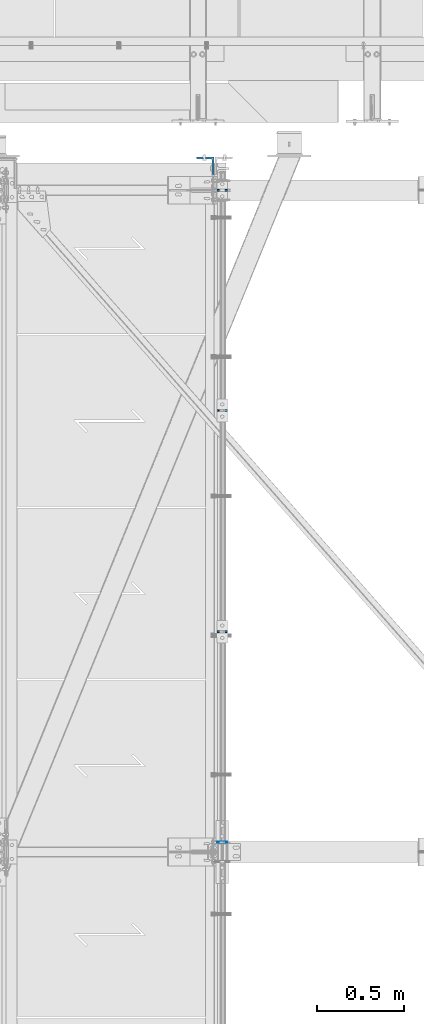
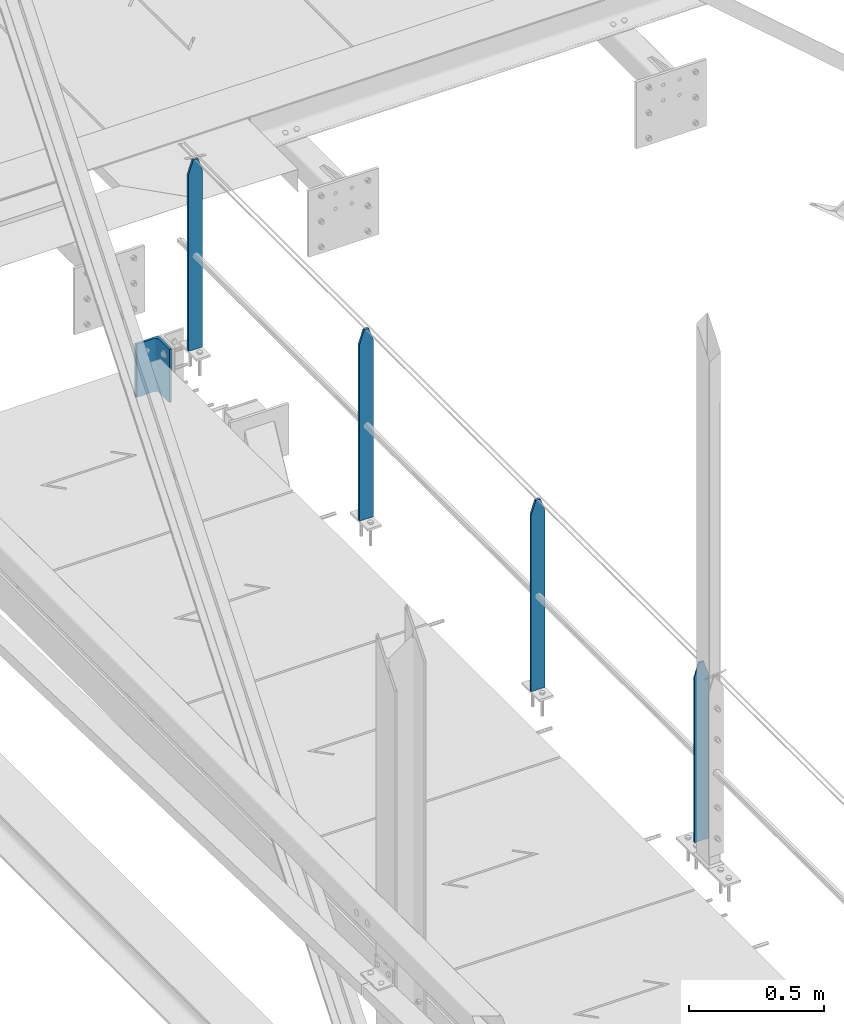
# One storey, part 27 of 496: 5 columns, 2 elements without a shape of their own.
"""IFC2X3 building model written with IfcOpenShell, lengths in millimetres."""

import ifcopenshell
import ifcopenshell.guid

model = None  # the IFC model being written
_history = None  # IfcOwnerHistory: only IFC2X3 demands one
_inside = {}  # id of a spatial element -> (the spatial element, [elements in it])
_under = {}  # id of a project, library or spatial element -> (it, [spatial elements below it])
_declared = {}  # id of a project -> (the project, [libraries it declares])
_typed = {}  # id of a type object -> (the type object, [elements of that type])
_made_of = {}  # id of a material, layer set ... -> (it, [elements and type objects made of it])


def new_model(schema):
    """Start an empty IFC model of exactly this schema.

    Asked for "IFC4X3", IfcOpenShell would pick the latest addendum, in which some entities
    have other attributes; the version numbers below select the first issue.
    IFC2X3 requires an IfcOwnerHistory on every rooted entity: one is made here for all.
    """
    global model, _history
    if schema == "IFC4X3":
        model = ifcopenshell.file(schema_version=(4, 3, 0, 0))
    else:
        model = ifcopenshell.file(schema=schema)
    _inside.clear()
    _under.clear()
    _declared.clear()
    _typed.clear()
    _made_of.clear()
    _history = None
    if model.schema == "IFC2X3":
        org = make("IfcOrganization", Name="unknown")
        user = make(
            "IfcPersonAndOrganization",
            ThePerson=make("IfcPerson", FamilyName="unknown"),
            TheOrganization=org,
        )
        app = make(
            "IfcApplication",
            ApplicationDeveloper=org,
            Version="unknown",
            ApplicationFullName="unknown",
            ApplicationIdentifier="unknown",
        )
        _history = make(
            "IfcOwnerHistory",
            OwningUser=user,
            OwningApplication=app,
            ChangeAction="ADDED",
            CreationDate=0,
        )
    return model


def make(cls, **values):
    """One entity of the class cls with the attributes given. An attribute that is None is left unset."""
    return model.create_entity(
        cls, **{name: value for name, value in values.items() if value is not None}
    )


def rooted(cls, **values):
    """An entity with a GlobalId (a new one), such as an element, a storey or a relation."""
    return make(cls, GlobalId=ifcopenshell.guid.new(), OwnerHistory=_history, **values)


def si_unit(unit_type, name, prefix=None):
    """IfcSIUnit, for example si_unit("LENGTHUNIT", "METRE", prefix="MILLI")."""
    return make("IfcSIUnit", UnitType=unit_type, Prefix=prefix, Name=name)


def assignment(units):
    """IfcUnitAssignment: the units of a project."""
    return None if units is None else make("IfcUnitAssignment", Units=units)


def point(xyz):
    """IfcCartesianPoint."""
    return None if xyz is None else make("IfcCartesianPoint", Coordinates=xyz)


def direction(xyz):
    """IfcDirection."""
    return None if xyz is None else make("IfcDirection", DirectionRatios=xyz)


def frame(location, z_axis=None, x_axis=None):
    """IfcAxis2Placement3D, a coordinate frame: its origin and axes. An axis left out is left unset."""
    return make(
        "IfcAxis2Placement3D",
        Location=point(location),
        Axis=direction(z_axis),
        RefDirection=direction(x_axis),
    )


def frame_2d(location, x_axis=None):
    """IfcAxis2Placement2D, a coordinate frame in the plane: its origin and x axis."""
    return make(
        "IfcAxis2Placement2D", Location=point(location), RefDirection=direction(x_axis)
    )


def origin_with_axes():
    """The frame at (0, 0, 0) with the z axis (0, 0, 1) and the x axis (1, 0, 0) written out."""
    return frame((0.0, 0.0, 0.0), z_axis=(0.0, 0.0, 1.0), x_axis=(1.0, 0.0, 0.0))


def origin_2d_with_axis():
    """The frame at (0, 0) in the plane with the x axis (1, 0) written out."""
    return frame_2d((0.0, 0.0), x_axis=(1.0, 0.0))


def place(relative_to, where):
    """IfcLocalPlacement: puts the frame where relative to a parent placement (None: the world)."""
    return make(
        "IfcLocalPlacement", PlacementRelTo=relative_to, RelativePlacement=where
    )


def context(
    kind, dimensions, precision=None, world=None, true_north=None, identifier=None
):
    """IfcGeometricRepresentationContext, for example the 3D "Model" context."""
    return make(
        "IfcGeometricRepresentationContext",
        ContextIdentifier=identifier,
        ContextType=kind,
        CoordinateSpaceDimension=dimensions,
        Precision=precision,
        WorldCoordinateSystem=world,
        TrueNorth=true_north,
    )


def subcontext(parent, identifier, kind, view, scale=None):
    """IfcGeometricRepresentationSubContext, for example "Body" below "Model"."""
    return make(
        "IfcGeometricRepresentationSubContext",
        ContextIdentifier=identifier,
        ContextType=kind,
        ParentContext=parent,
        TargetScale=scale,
        TargetView=view,
    )


def project(units=None, contexts=None):
    """IfcProject with its units and contexts."""
    return rooted(
        "IfcProject",
        Name="project",
        RepresentationContexts=contexts,
        UnitsInContext=assignment(units),
    )


def spatial(cls, under=None, at=None, **own):
    """A site, building, storey or space (cls), placed at a placement, below another one or the project."""
    s = rooted(cls, ObjectPlacement=at, **own)
    if under is not None:
        _under.setdefault(under.id(), (under, []))[1].append(s)
    return s


def profile(cls, at=None, kind="AREA", **sizes):
    """A parametric profile (cls). Its sizes go by their IFC names, for example OverallWidth=200.0."""
    return make(cls, ProfileType=kind, Position=at, **sizes)


def rectangle(**sizes):
    """IfcRectangleProfileDef."""
    return profile("IfcRectangleProfileDef", **sizes)


def l_section(**sizes):
    """IfcLShapeProfileDef."""
    return profile("IfcLShapeProfileDef", **sizes)


def extrude(swept, where, along, depth):
    """IfcExtrudedAreaSolid: the profile swept, set in the frame where, extruded along a direction by depth."""
    return make(
        "IfcExtrudedAreaSolid",
        SweptArea=swept,
        Position=where,
        ExtrudedDirection=direction(along),
        Depth=depth,
    )


def clip(a, b, op="DIFFERENCE"):
    """IfcBooleanClippingResult: the solid a cut by the half space b."""
    return make(
        "IfcBooleanClippingResult", Operator=op, FirstOperand=a, SecondOperand=b
    )


def halfspace(plane, agree):
    """IfcHalfSpaceSolid: all space on one side of the plane z = 0 of the frame plane."""
    return make(
        "IfcHalfSpaceSolid",
        BaseSurface=make("IfcPlane", Position=plane),
        AgreementFlag=agree,
    )


def shape(context_of_items, identifier, shape_type, items):
    """IfcShapeRepresentation: the items that make up one representation, for example the "Body"."""
    return make(
        "IfcShapeRepresentation",
        ContextOfItems=context_of_items,
        RepresentationIdentifier=identifier,
        RepresentationType=shape_type,
        Items=items,
    )


def material(Name=None, Category=None):
    """IfcMaterial."""
    return make("IfcMaterial", Name=Name, Category=Category)


def made_of(thing, what):
    """Note that an element or type object is made of a material, layer set ...; save() writes the relation."""
    if what is not None:
        _made_of.setdefault(what.id(), (what, []))[1].append(thing)
    return thing


def type_object(cls, material=None, **own):
    """A type object (cls), such as IfcWallType, which elements share."""
    return made_of(rooted(cls, **own), material)


def element(
    cls,
    number,
    at=None,
    inside=None,
    cuts=None,
    type_object=None,
    material=None,
    context=None,
    identifier="Body",
    shape_type=None,
    held_by="IfcProductDefinitionShape",
    body=None,
    shapes=None,
    **own,
):
    """One element of the class cls, such as IfcWall. Its Tag is "e" and its number.

    at: its placement. inside: the storey or other place that contains it. cuts: it is an
    opening in that element (IfcRelVoidsElement). A single representation is given by context,
    identifier, shape_type and body (its items); several are given by shapes. held_by: the class
    of the entity that holds the representations. save() writes the other relations.
    """
    e = rooted(cls, Tag="e%d" % number, ObjectPlacement=at, **own)
    if body is not None:
        shapes = [shape(context, identifier, shape_type, body)]
    if shapes is not None:
        e.Representation = make(held_by, Representations=shapes)
    if inside is not None:
        _inside.setdefault(inside.id(), (inside, []))[1].append(e)
    if cuts is not None:
        rooted(
            "IfcRelVoidsElement", RelatingBuildingElement=cuts, RelatedOpeningElement=e
        )
    if type_object is not None:
        _typed.setdefault(type_object.id(), (type_object, []))[1].append(e)
    return made_of(e, material)


def aggregate(whole, parts):
    """IfcRelAggregates: a whole, such as a stair, and the parts it consists of."""
    return rooted("IfcRelAggregates", RelatingObject=whole, RelatedObjects=parts)


def save(model, path):
    """Write the relations noted so far, then the file.

    IfcRelAggregates (storeys below a building ...), IfcRelContainedInSpatialStructure (elements
    in a storey), IfcRelDefinesByType, IfcRelAssociatesMaterial and IfcRelDeclares: one each for
    every whole, place, type object, material and project.
    """
    for whole, parts in _under.values():
        aggregate(whole, parts)
    for where, things in _inside.values():
        rooted(
            "IfcRelContainedInSpatialStructure",
            RelatedElements=things,
            RelatingStructure=where,
        )
    for kind, things in _typed.values():
        rooted("IfcRelDefinesByType", RelatedObjects=things, RelatingType=kind)
    for what, things in _made_of.values():
        rooted("IfcRelAssociatesMaterial", RelatedObjects=things, RelatingMaterial=what)
    for by, libraries in _declared.values():
        rooted("IfcRelDeclares", RelatingContext=by, RelatedDefinitions=libraries)
    model.write(path)


model = new_model("IFC2X3")

# Units and contexts
model_context = context("Model", 3, precision=1e-05, world=origin_with_axes())
body_context = subcontext(model_context, "Body", "Model", "MODEL_VIEW")
ifc_project = project(units=[si_unit("LENGTHUNIT", "METRE", prefix="MILLI"), si_unit("AREAUNIT", "SQUARE_METRE"), si_unit("VOLUMEUNIT", "CUBIC_METRE"), si_unit("MASSUNIT", "GRAM", prefix="KILO"), si_unit("TIMEUNIT", "SECOND"), si_unit("PLANEANGLEUNIT", "RADIAN"), si_unit("SOLIDANGLEUNIT", "STERADIAN"), si_unit("THERMODYNAMICTEMPERATUREUNIT", "DEGREE_CELSIUS"), si_unit("LUMINOUSINTENSITYUNIT", "LUMEN")], contexts=[model_context])

# Site, building, storey
site_placement = place(None, origin_with_axes())
site = spatial("IfcSite", under=ifc_project, at=site_placement, CompositionType="ELEMENT")
building_placement = place(site_placement, origin_with_axes())
building = spatial("IfcBuilding", under=site, at=building_placement, Name="Undefined", CompositionType="ELEMENT")
storey_placement = place(building_placement, origin_with_axes())
storey = spatial("IfcBuildingStorey", under=building, at=storey_placement, Name="Undefined", CompositionType="ELEMENT", Elevation=0.0)

# Assembly, columns
assembly_1_placement = place(storey_placement, origin_with_axes())
assembly_1 = element("IfcElementAssembly", 1, at=assembly_1_placement, inside=storey, Name="MAIN COURANTE", AssemblyPlace="NOTDEFINED", PredefinedType="NOTDEFINED")
ifc_material = material(Name="Undefined/S235-E24")
column_type_1 = type_object("IfcColumnType", PredefinedType="NOTDEFINED")
column_1_placement = place(assembly_1_placement, frame((13993.999893639, 15200.0000000319, 8249.99999828729), z_axis=(0.0, 0.0, 1.0), x_axis=(1.0, 0.0, 0.0)))
column_1 = element("IfcColumn", 2, at=column_1_placement, type_object=column_type_1, material=ifc_material, Name="MONTANT", context=body_context, shape_type="Clipping", body=[
    clip(clip(extrude(rectangle(XDim=10.0, YDim=60.0, at=origin_2d_with_axis()), frame((0.0, 0.0, 857.599997130677), z_axis=(0.0, 0.0, -1.0), x_axis=(0.0, 1.0, 0.0)), (0.0, 0.0, 1.0), 857.6), halfspace(frame((30.0000001657245, -5.000000004674, 797.599997170884), z_axis=(0.948683298050514, 0.0, 0.316227766016838), x_axis=(-0.316227766016838, 0.0, 0.948683298050514)), False)), halfspace(frame((-29.9999998342682, 4.99999999524351, 797.599997177174), z_axis=(-0.948683298050514, 0.0, 0.316227766016838), x_axis=(0.316227766016838, 0.0, 0.948683298050514)), False)),
])
column_2_placement = place(assembly_1_placement, frame((13993.9998916118, 12665.0034471708, 8250.00000011892), z_axis=(0.0, 0.0, 1.0), x_axis=(1.0, 0.0, 0.0)))
column_2 = element("IfcColumn", 3, at=column_2_placement, type_object=column_type_1, material=ifc_material, Name="MONTANT", context=body_context, shape_type="Clipping", body=[
    clip(clip(extrude(rectangle(XDim=10.0, YDim=60.0, at=origin_2d_with_axis()), frame((0.0, 0.0, 857.599997130677), z_axis=(0.0, 0.0, -1.0), x_axis=(0.0, 1.0, 0.0)), (0.0, 0.0, 1.0), 857.6), halfspace(frame((30.0000001657245, -5.000000004674, 797.599997170884), z_axis=(0.948683298050514, 0.0, 0.316227766016838), x_axis=(-0.316227766016838, 0.0, 0.948683298050514)), False)), halfspace(frame((-29.9999998342682, 4.99999999524351, 797.599997177174), z_axis=(-0.948683298050514, 0.0, 0.316227766016838), x_axis=(0.316227766016838, 0.0, 0.948683298050514)), False)),
])
column_3_placement = place(assembly_1_placement, frame((13993.999892667, 13935.0034471708, 8249.99999924836), z_axis=(0.0, 0.0, 1.0), x_axis=(1.0, 0.0, 0.0)))
column_3 = element("IfcColumn", 4, at=column_3_placement, type_object=column_type_1, material=ifc_material, Name="MONTANT", context=body_context, shape_type="Clipping", body=[
    clip(clip(extrude(rectangle(XDim=10.0, YDim=60.0, at=origin_2d_with_axis()), frame((0.0, 0.0, 857.599997130677), z_axis=(0.0, 0.0, -1.0), x_axis=(0.0, 1.0, 0.0)), (0.0, 0.0, 1.0), 857.6), halfspace(frame((30.0000001657245, -5.000000004674, 797.599997170884), z_axis=(0.948683298050514, 0.0, 0.316227766016838), x_axis=(-0.316227766016838, 0.0, 0.948683298050514)), False)), halfspace(frame((-29.9999998342682, 4.99999999524351, 797.599997177174), z_axis=(-0.948683298050514, 0.0, 0.316227766016838), x_axis=(0.316227766016838, 0.0, 0.948683298050514)), False)),
])
column_type_2 = type_object("IfcColumnType", PredefinedType="NOTDEFINED")
column_4_placement = place(assembly_1_placement, frame((13993.9998909582, 11455.0000089118, 8300.00000102069), z_axis=(0.0, 0.0, 1.0), x_axis=(1.0, 0.0, 0.0)))
column_4 = element("IfcColumn", 5, at=column_4_placement, type_object=column_type_2, material=ifc_material, Name="MONTANT", context=body_context, shape_type="Clipping", body=[
    clip(clip(extrude(rectangle(XDim=5.0, YDim=60.0, at=origin_2d_with_axis()), frame((0.0, 0.0, 807.599997128624), z_axis=(0.0, 0.0, -1.0), x_axis=(0.0, 1.0, 0.0)), (0.0, 0.0, 1.0), 807.6), halfspace(frame((29.9999999717475, -5.00000000468981, 747.599997131425), z_axis=(0.948683298050514, 0.0, 0.316227766016838), x_axis=(-0.316227766016838, 0.0, 0.948683298050514)), False)), halfspace(frame((-30.000000028238, 4.99999999522788, 747.599997137713), z_axis=(-0.948683298050514, 0.0, 0.316227766016838), x_axis=(0.316227766016838, 0.0, 0.948683298050514)), False)),
])
aggregate(assembly_1, [column_1, column_4, column_2, column_3])

# Assembly, column
assembly_2_placement = place(storey_placement, origin_with_axes())
assembly_2 = element("IfcElementAssembly", 6, at=assembly_2_placement, inside=storey, AssemblyPlace="NOTDEFINED", PredefinedType="NOTDEFINED")
column_type_3 = type_object("IfcColumnType", PredefinedType="NOTDEFINED")
column_5_placement = place(assembly_2_placement, frame((13896.4998855292, 15339.9999998808, 7970.00437164953), z_axis=(0.0, 0.0, 1.0), x_axis=(-1.0, 0.0, 0.0)))
column_5 = element("IfcColumn", 7, at=column_5_placement, type_object=column_type_3, material=ifc_material, context=body_context, shape_type="SweptSolid", body=[
    extrude(l_section(Depth=100.0, Width=100.0, Thickness=10.0, FilletRadius=12.0, EdgeRadius=6.0, at=origin_2d_with_axis()), frame((0.0, 0.0, 239.999999999999), z_axis=(0.0, 0.0, -1.0), x_axis=(0.0, 1.0, 0.0)), (0.0, 0.0, 1.0), 240.0),
])
aggregate(assembly_2, [column_5])

save(model, "model.ifc")
